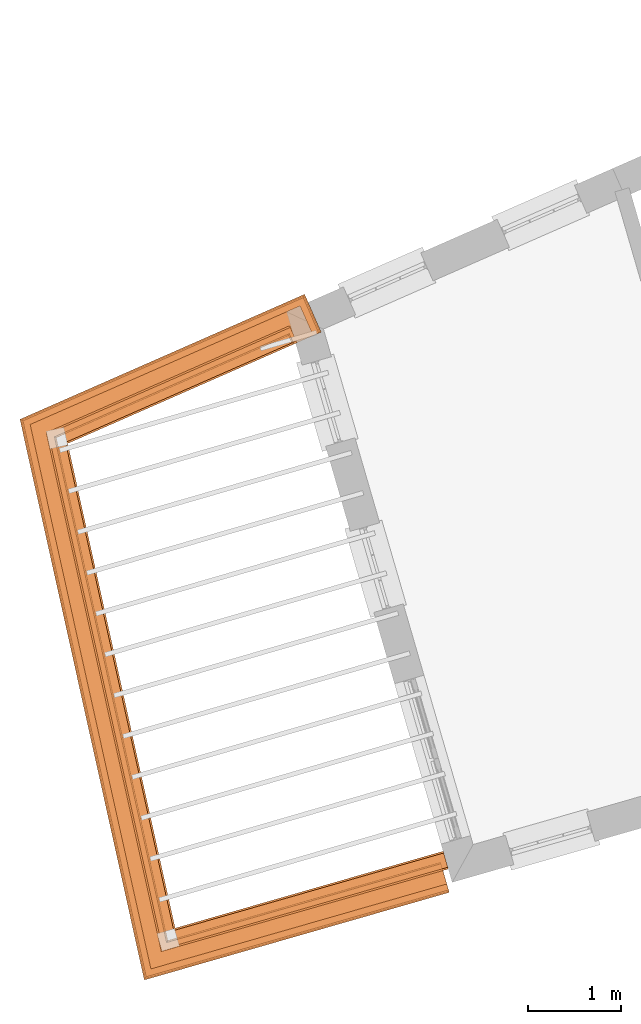
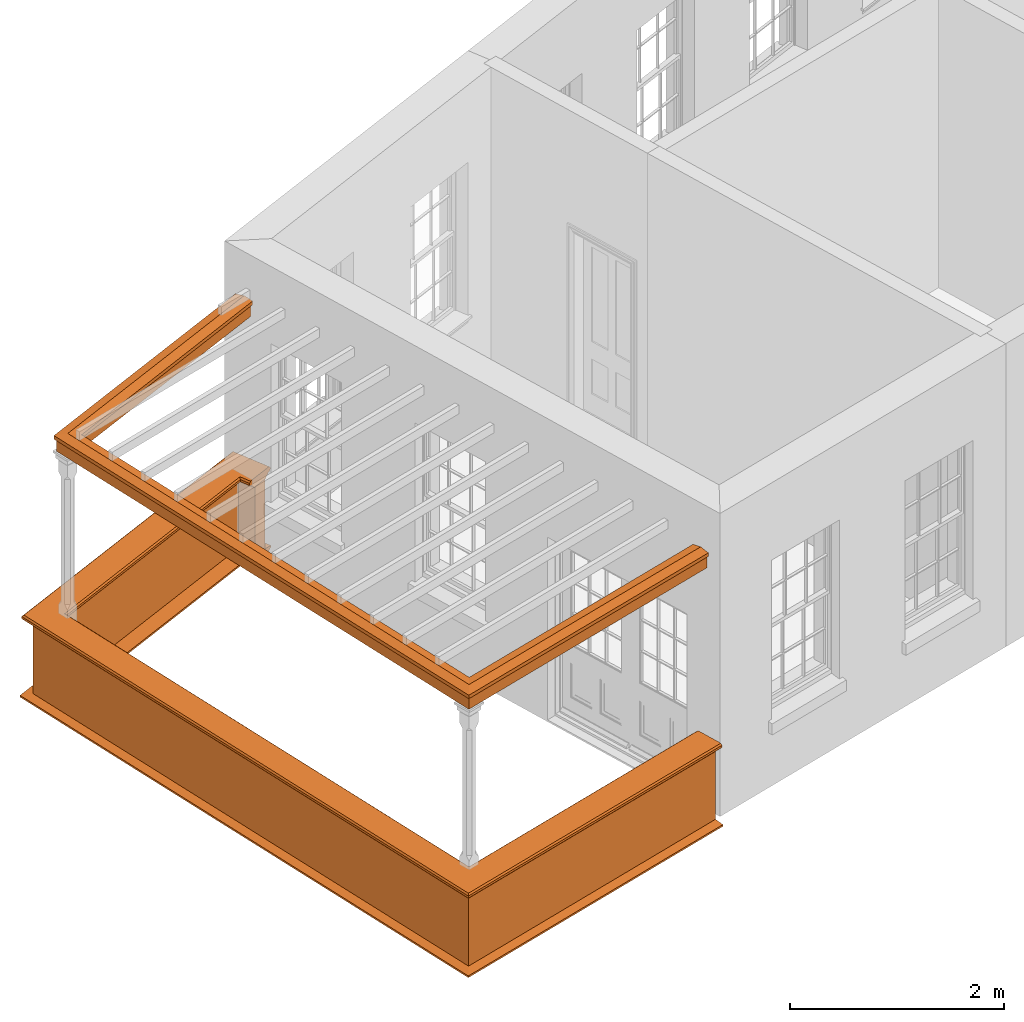
# One storey, part 10 of 11: 5 proxies.
"""IFC2X3 building model written with IfcOpenShell, lengths in metres."""

from ifc_helpers import new_model, entity, si_unit, frame, origin, place, context, subcontext, project, spatial, element, save


model = new_model("IFC2X3")

# Units and contexts
model_context = context("Model", 3, world=origin())
body_context = subcontext(model_context, "Body", "Model", "MODEL_VIEW")
ifc_project = project(units=[si_unit("PLANEANGLEUNIT", "RADIAN"), si_unit("MASSUNIT", "GRAM", prefix="KILO"), si_unit("FORCEUNIT", "NEWTON", prefix="KILO"), si_unit("LENGTHUNIT", "METRE")], contexts=[model_context])

# Site, building, storey
site_placement = place(None, origin())
site = spatial("IfcSite", under=ifc_project, at=site_placement, CompositionType="ELEMENT")
building_placement = place(None, origin())
building = spatial("IfcBuilding", under=site, at=building_placement, Name="Building plot-15", CompositionType="ELEMENT")
storey_placement = place(None, frame((0.0, 0.0, 7.6)))
storey = spatial("IfcBuildingStorey", under=building, at=storey_placement, Name="Floor 1", CompositionType="ELEMENT", Elevation=7.6)

# Proxies
proxy_1_placement = place(storey_placement, origin())
axis2_placement3_d_1 = entity("IfcAxis2Placement3D", entity("IfcCartesianPoint", [0.0, 0.0, 0.0]))
element("IfcBuildingElementProxy", 1, at=proxy_1_placement, inside=storey, Name="parapet", CompositionType="ELEMENT", context=body_context, shape_type="SweptSolid", held_by="IfcProductRepresentation", body=[
    entity("IfcSurfaceCurveSweptAreaSolid", entity("IfcArbitraryClosedProfileDef", "AREA", None, entity("IfcPolyline", [entity("IfcCartesianPoint", [0.0, 0.25]), entity("IfcCartesianPoint", [0.795, 0.25]), entity("IfcCartesianPoint", [0.795, 0.09]), entity("IfcCartesianPoint", [0.02, 0.09]), entity("IfcCartesianPoint", [0.02, -0.08]), entity("IfcCartesianPoint", [0.0, -0.08]), entity("IfcCartesianPoint", [0.0, 0.25])])), axis2_placement3_d_1, entity("IfcPolyline", [entity("IfcCartesianPoint", [85.3474419937153, 55.851628698113]), entity("IfcCartesianPoint", [85.3072109178944, 55.9431790150884]), entity("IfcCartesianPoint", [82.8159321906737, 54.848405925525]), entity("IfcCartesianPoint", [84.0149116510646, 49.4418036204089]), entity("IfcCartesianPoint", [86.947754451885, 50.2841783600836])]), 0.0, 1.0, entity("IfcPlane", axis2_placement3_d_1)),
])
proxy_2_placement = place(storey_placement, origin())
axis2_placement3_d_2 = entity("IfcAxis2Placement3D", entity("IfcCartesianPoint", [0.0, 0.0, 0.0]))
element("IfcBuildingElementProxy", 2, at=proxy_2_placement, inside=storey, Name="parapet", CompositionType="ELEMENT", context=body_context, shape_type="SweptSolid", held_by="IfcProductRepresentation", body=[
    entity("IfcSurfaceCurveSweptAreaSolid", entity("IfcArbitraryClosedProfileDef", "AREA", None, entity("IfcPolyline", [entity("IfcCartesianPoint", [0.795, 0.265]), entity("IfcCartesianPoint", [0.807, 0.268]), entity("IfcCartesianPoint", [0.816, 0.274]), entity("IfcCartesianPoint", [0.822, 0.283]), entity("IfcCartesianPoint", [0.825, 0.295]), entity("IfcCartesianPoint", [0.84, 0.295]), entity("IfcCartesianPoint", [0.84, 0.305]), entity("IfcCartesianPoint", [0.842, 0.317]), entity("IfcCartesianPoint", [0.849, 0.326]), entity("IfcCartesianPoint", [0.858, 0.333]), entity("IfcCartesianPoint", [0.87, 0.335]), entity("IfcCartesianPoint", [0.882, 0.333]), entity("IfcCartesianPoint", [0.891, 0.326]), entity("IfcCartesianPoint", [0.898, 0.317]), entity("IfcCartesianPoint", [0.9, 0.305]), entity("IfcCartesianPoint", [0.9, 0.035]), entity("IfcCartesianPoint", [0.898, 0.023]), entity("IfcCartesianPoint", [0.891, 0.014]), entity("IfcCartesianPoint", [0.882, 0.007]), entity("IfcCartesianPoint", [0.87, 0.005]), entity("IfcCartesianPoint", [0.858, 0.007]), entity("IfcCartesianPoint", [0.849, 0.014]), entity("IfcCartesianPoint", [0.842, 0.023]), entity("IfcCartesianPoint", [0.84, 0.035]), entity("IfcCartesianPoint", [0.84, 0.045]), entity("IfcCartesianPoint", [0.825, 0.045]), entity("IfcCartesianPoint", [0.822, 0.057]), entity("IfcCartesianPoint", [0.816, 0.066]), entity("IfcCartesianPoint", [0.807, 0.072]), entity("IfcCartesianPoint", [0.795, 0.075]), entity("IfcCartesianPoint", [0.795, 0.265])])), axis2_placement3_d_2, entity("IfcPolyline", [entity("IfcCartesianPoint", [85.3474419937153, 55.851628698113]), entity("IfcCartesianPoint", [85.3072109178944, 55.9431790150884]), entity("IfcCartesianPoint", [82.8159321906737, 54.848405925525]), entity("IfcCartesianPoint", [84.0149116510646, 49.4418036204089]), entity("IfcCartesianPoint", [86.947754451885, 50.2841783600836])]), 0.0, 1.0, entity("IfcPlane", axis2_placement3_d_2)),
])
proxy_3_placement = place(storey_placement, origin())
axis2_placement3_d_3 = entity("IfcAxis2Placement3D", entity("IfcCartesianPoint", [0.0, 0.0, 0.0]))
element("IfcBuildingElementProxy", 3, at=proxy_3_placement, inside=storey, Name="parapet", CompositionType="ELEMENT", context=body_context, shape_type="SweptSolid", held_by="IfcProductRepresentation", body=[
    entity("IfcSurfaceCurveSweptAreaSolid", entity("IfcArbitraryClosedProfileDef", "AREA", None, entity("IfcPolyline", [entity("IfcCartesianPoint", [-0.1, 0.25]), entity("IfcCartesianPoint", [-0.1, 0.265]), entity("IfcCartesianPoint", [-0.085, 0.265]), entity("IfcCartesianPoint", [-0.084, 0.278]), entity("IfcCartesianPoint", [-0.081, 0.289]), entity("IfcCartesianPoint", [-0.074, 0.301]), entity("IfcCartesianPoint", [-0.065, 0.309]), entity("IfcCartesianPoint", [-0.055, 0.315]), entity("IfcCartesianPoint", [-0.044, 0.324]), entity("IfcCartesianPoint", [-0.038, 0.334]), entity("IfcCartesianPoint", [-0.035, 0.345]), entity("IfcCartesianPoint", [-0.015, 0.345]), entity("IfcCartesianPoint", [0.0, 0.25]), entity("IfcCartesianPoint", [-0.1, 0.25])])), axis2_placement3_d_3, entity("IfcPolyline", [entity("IfcCartesianPoint", [85.3474419937153, 55.851628698113]), entity("IfcCartesianPoint", [85.3072109178944, 55.9431790150884]), entity("IfcCartesianPoint", [82.8159321906737, 54.848405925525]), entity("IfcCartesianPoint", [84.0149116510646, 49.4418036204089]), entity("IfcCartesianPoint", [86.947754451885, 50.2841783600836])]), 0.0, 1.0, entity("IfcPlane", axis2_placement3_d_3)),
])
proxy_4_placement = place(storey_placement, frame((0.0, 0.0, 3.45)))
axis2_placement3_d_4 = entity("IfcAxis2Placement3D", entity("IfcCartesianPoint", [0.0, 0.0, 0.0]))
element("IfcBuildingElementProxy", 4, at=proxy_4_placement, inside=storey, Name="pergola beam", CompositionType="ELEMENT", context=body_context, shape_type="SweptSolid", held_by="IfcProductRepresentation", body=[
    entity("IfcSurfaceCurveSweptAreaSolid", entity("IfcArbitraryClosedProfileDef", "AREA", None, entity("IfcPolyline", [entity("IfcCartesianPoint", [-0.7, -0.08]), entity("IfcCartesianPoint", [-0.7, 0.08]), entity("IfcCartesianPoint", [-0.56, 0.08]), entity("IfcCartesianPoint", [-0.56, -0.08]), entity("IfcCartesianPoint", [-0.7, -0.08])])), axis2_placement3_d_4, entity("IfcPolyline", [entity("IfcCartesianPoint", [85.3621411080797, 55.9673176605809]), entity("IfcCartesianPoint", [82.8159321906737, 54.848405925525]), entity("IfcCartesianPoint", [84.0149116510646, 49.4418036204089]), entity("IfcCartesianPoint", [87.0054228771403, 50.3007419565703])]), 0.0, 1.0, entity("IfcPlane", axis2_placement3_d_4)),
])
proxy_5_placement = place(storey_placement, frame((0.0, 0.0, 3.45)))
axis2_placement3_d_5 = entity("IfcAxis2Placement3D", entity("IfcCartesianPoint", [0.0, 0.0, 0.0]))
element("IfcBuildingElementProxy", 5, at=proxy_5_placement, inside=storey, Name="pergola beam", CompositionType="ELEMENT", context=body_context, shape_type="SweptSolid", held_by="IfcProductRepresentation", body=[
    entity("IfcSurfaceCurveSweptAreaSolid", entity("IfcArbitraryClosedProfileDef", "AREA", None, entity("IfcPolyline", [entity("IfcCartesianPoint", [-0.5, 0.0]), entity("IfcCartesianPoint", [-0.52, -0.1]), entity("IfcCartesianPoint", [-0.56, -0.1]), entity("IfcCartesianPoint", [-0.56, 0.1]), entity("IfcCartesianPoint", [-0.52, 0.1]), entity("IfcCartesianPoint", [-0.5, 0.0])])), axis2_placement3_d_5, entity("IfcPolyline", [entity("IfcCartesianPoint", [85.3621411080797, 55.9673176605809]), entity("IfcCartesianPoint", [82.8159321906737, 54.848405925525]), entity("IfcCartesianPoint", [84.0149116510646, 49.4418036204089]), entity("IfcCartesianPoint", [87.0054228771403, 50.3007419565703])]), 0.0, 1.0, entity("IfcPlane", axis2_placement3_d_5)),
])

save(model, "model.ifc")
